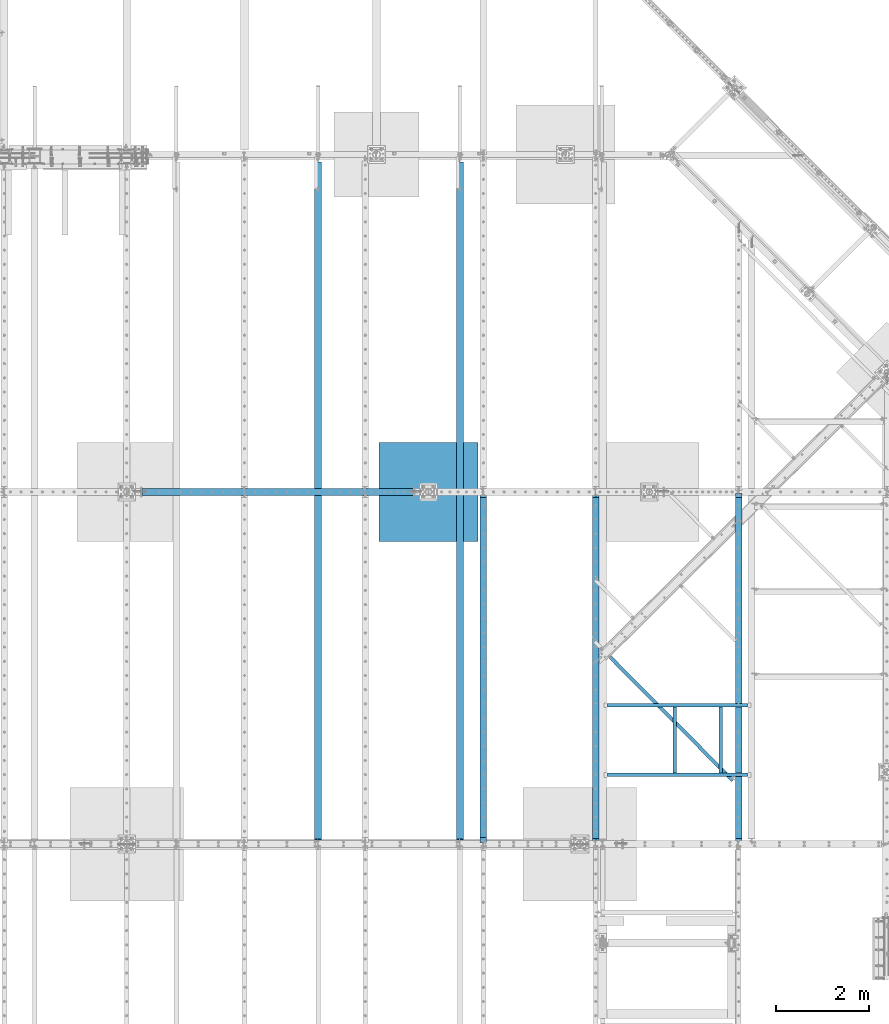
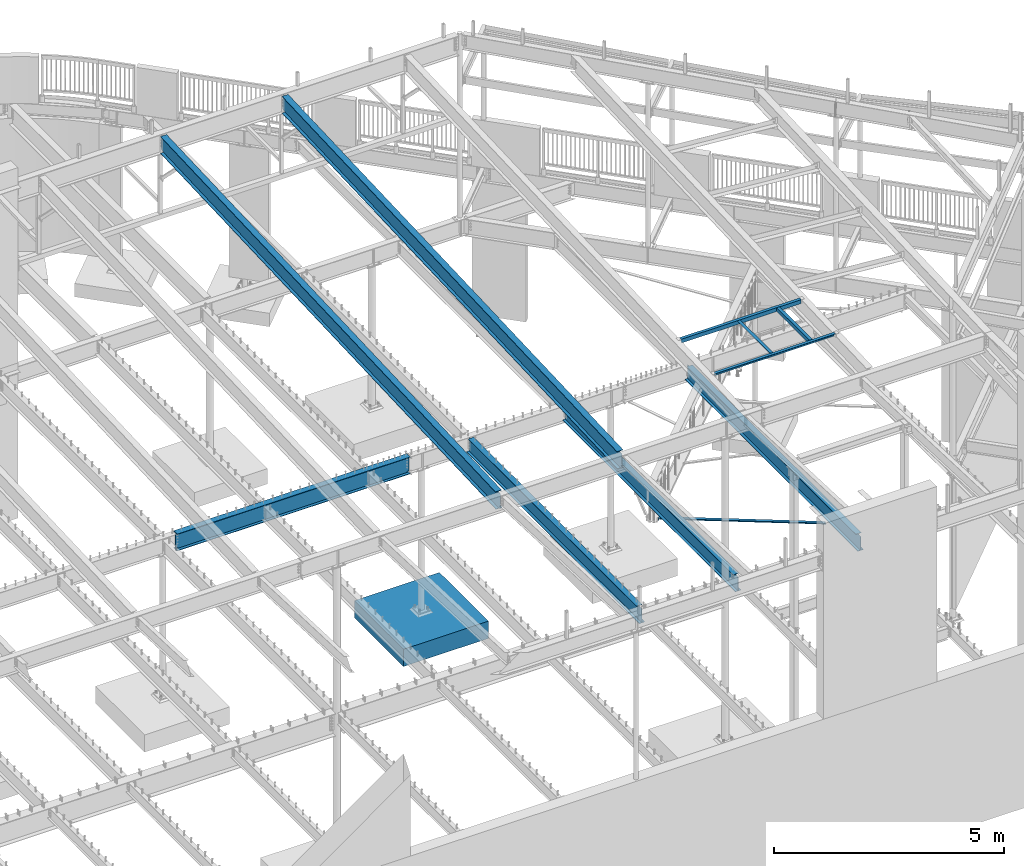
# One storey, part 317 of 975: 12 beams.
"""IFC2X3 building model written with IfcOpenShell, lengths in millimetres."""

from ifc_helpers import new_model, si_unit, frame, origin_with_axes, place, context, subcontext, project, spatial, faceted_brep, material, type_object, element, save


model = new_model("IFC2X3")

# Units and contexts
model_context = context("Model", 3, precision=1e-05, world=origin_with_axes())
body_context = subcontext(model_context, "Body", "Model", "MODEL_VIEW")
ifc_project = project(units=[si_unit("LENGTHUNIT", "METRE", prefix="MILLI"), si_unit("AREAUNIT", "SQUARE_METRE"), si_unit("VOLUMEUNIT", "CUBIC_METRE"), si_unit("MASSUNIT", "GRAM", prefix="KILO"), si_unit("TIMEUNIT", "SECOND"), si_unit("PLANEANGLEUNIT", "RADIAN"), si_unit("SOLIDANGLEUNIT", "STERADIAN"), si_unit("THERMODYNAMICTEMPERATUREUNIT", "DEGREE_CELSIUS"), si_unit("LUMINOUSINTENSITYUNIT", "LUMEN")], contexts=[model_context])

# Site, building, storey
site_placement = place(None, origin_with_axes())
site = spatial("IfcSite", under=ifc_project, at=site_placement, CompositionType="ELEMENT")
building_placement = place(site_placement, origin_with_axes())
building = spatial("IfcBuilding", under=site, at=building_placement, Name="Undefined", CompositionType="ELEMENT")
storey_placement = place(building_placement, origin_with_axes())
storey = spatial("IfcBuildingStorey", under=building, at=storey_placement, Name="Undefined", CompositionType="ELEMENT", Elevation=0.0)

# Beams
ifc_material_1 = material(Name="STEEL/A36")
beam_type_1 = type_object("IfcBeamType", Name="L3X3X3/16", PredefinedType="NOTDEFINED")
beam_1_placement = place(storey_placement, frame((23906.3912854888, 9816.87831160247, 2870.2), z_axis=(-0.709199630836852, -0.705007718837796, 0.0), x_axis=(0.0, 0.0, 1.0)))
element("IfcBeam", 1, at=beam_1_placement, inside=storey, type_object=beam_type_1, material=ifc_material_1, Name="ANGLE", ObjectType="L3X3X3/16", context=body_context, shape_type="Brep", body=[
    faceted_brep([(25.3999991016485, 33.3375000005835, 38.1000564628812), (25.4000018705901, 38.1000000005915, 38.1000564628885), (25.4000018418292, 38.100000000657, -38.0999435372178), (25.3999990728876, 33.3374606629004, -38.1001501021346), (25.3999990746852, 33.3375000006454, -33.3374435372207), (87.9656692672388, 33.3375000124943, -33.3373044571854), (87.9656692654412, 33.3374606295438, -38.099937640236), (17.2974222805042, 22.8805155612699, -38.0999615488181), (17.2974222808862, 22.8805549429017, -33.3374615488137), (26.3940511142555, -38.5946475536875, -33.3371779727895), (26.3210864210287, -38.0999999994438, -33.3374414897553), (26.3211297871808, -38.0999999994419, -38.0999414896651), (26.3940672015779, -38.5946847264931, -38.0996779726156), (571.069093997022, -3719.51957603081, -38.0691073324269), (571.069077934182, -3719.51953902345, -33.3066073326008), (101.773291179968, -27.4406454407417, -38.0995104087415), (92.0753515031388, 38.1000000021377, -38.099795321592), (92.0746576447095, 38.1000000020686, 38.1002046769718), (101.773033782809, -27.4400506758284, 38.1004895884216), (646.448060967117, -3708.36494460809, 38.1310602286285), (646.448317972562, -3708.36553672579, -38.0689397685564), (641.73710041125, -3709.06262717499, -33.3064502414745), (641.736859468646, -3709.06207206465, 38.1310497558879), (97.0618322841592, -28.1371781311864, 38.1004791156811), (87.9650187874622, 33.3375000019751, 38.1001955414686), (97.0620735939965, -28.1377357232959, -33.3370208816596), (25.821086420955, -34.7225405137397, -33.3374426012269), (25.8210970077298, -34.7226514435897, -38.0999426012095)], [[[0, 1, 2, 3, 4]], [[5, 6, 7, 8]], [[4, 3, 6, 5]], [[9, 10, 11, 12, 13, 14]], [[15, 16, 17, 18, 19, 20]], [[21, 14, 13, 20, 19, 22]], [[23, 24, 5, 25, 21, 22]], [[26, 10, 9, 14, 21, 25, 5, 8]], [[27, 11, 10, 26, 8, 7]], [[2, 16, 15, 20, 13, 12, 11, 27, 7, 6, 3]], [[17, 16, 2, 1]], [[24, 23, 22, 19, 18, 17, 1, 0]], [[5, 24, 0, 4]]]),
])
beam_type_2 = type_object("IfcBeamType", Name="L4X3X1/4", PredefinedType="NOTDEFINED")
for number, where, z_axis, x_axis, name in (
    (2, (26260.425, 8766.17499989342, 8303.80592173534), (0.0, 0.0, -1.0), (0.0, -1.0, 0.0), "ANGLE"),
    (3, (25269.825, 7343.77500010658, 8303.80592173534), (0.0, 0.0, -1.0), (0.0, 1.0, 0.0), "ANGLE"),
):
    element("IfcBeam", number, at=place(storey_placement, frame(where, z_axis=z_axis, x_axis=x_axis)), inside=storey, type_object=beam_type_2, material=ifc_material_1, Name=name, ObjectType="L4X3X1/4", context=body_context, shape_type="Brep", body=[
        faceted_brep([(0.0, 38.0999999999985, -50.7999999999993), (0.0, 38.0999999999985, 50.7999999999993), (1422.39999978684, 38.0999999999985, 50.7999999999993), (1422.39999978684, 38.0999999999985, -50.7999999999993), (0.0, 31.75, 50.7999999999993), (1422.39999978684, 31.75, 50.7999999999993), (0.0, 31.75, -44.4500000000007), (1422.39999978684, 31.75, -44.4500000000007), (0.0, -38.0999999999985, -44.4500000000007), (1422.39999978684, -38.0999999999985, -44.4500000000007), (0.0, -38.0999999999985, -50.7999999999993), (1422.39999978684, -38.0999999999985, -50.7999999999993)], [[[0, 1, 2, 3]], [[1, 4, 5, 2]], [[4, 6, 7, 5]], [[6, 8, 9, 7]], [[8, 10, 11, 9]], [[10, 0, 3, 11]], [[5, 7, 9, 11, 3, 2]], [[10, 8, 6, 4, 1, 0]]]),
    ])
for number, where, z_axis, x_axis, name in (
    (4, (26838.275, 7305.67500010658, 8303.80592173534), (0.0, 0.0, -1.0), (-0.999999999999998, 6.90000001668524e-08, 0.0), "ANGLE"),
    (5, (23825.2, 8804.27499989342, 8303.80592173534), (0.0, 0.0, -1.0), (1.0, 0.0, 0.0), "FRAME"),
):
    element("IfcBeam", number, at=place(storey_placement, frame(where, z_axis=z_axis, x_axis=x_axis)), inside=storey, type_object=beam_type_2, material=ifc_material_1, Name=name, ObjectType="L4X3X1/4", context=body_context, shape_type="Brep", body=[
        faceted_brep([(0.0, 38.0999999999985, -50.7999999999993), (0.0, 38.0999999999985, 50.7999999999993), (3013.075, 38.1000000000004, 50.7999999999993), (3013.075, 38.1000000000004, -50.7999999999993), (0.0, 31.75, 50.7999999999993), (3013.075, 31.75, 50.7999999999993), (0.0, 31.75, -44.4500000000007), (3013.075, 31.75, -44.4500000000007), (0.0, -38.0999999999985, -44.4500000000007), (3013.075, -38.1000000000004, -44.4500000000007), (0.0, -38.0999999999985, -50.7999999999993), (3013.075, -38.1000000000004, -50.7999999999993)], [[[0, 1, 2, 3]], [[1, 4, 5, 2]], [[4, 6, 7, 5]], [[6, 8, 9, 7]], [[8, 10, 11, 9]], [[10, 0, 3, 11]], [[5, 7, 9, 11, 3, 2]], [[10, 8, 6, 4, 1, 0]]]),
    ])
ifc_material_2 = material(Name="STEEL/A992")
beam_type_3 = type_object("IfcBeamType", Name="W18X40", PredefinedType="NOTDEFINED")
beam_2_placement = place(storey_placement, frame((20653.375, 5829.11637334778, 8002.77977754138), z_axis=(0.0, -0.0411491589862163, 0.999153014665285), x_axis=(0.0, 0.999153014665285, 0.0411491589862177)))
element("IfcBeam", 6, at=beam_2_placement, inside=storey, type_object=beam_type_3, material=ifc_material_2, Name="BEAM", ObjectType="W18X40", context=body_context, shape_type="Brep", body=[
    faceted_brep([(14657.5609744888, -76.2000000000007, -214.312499994021), (14657.5609744888, -76.2000000000007, -227.012499992623), (14657.5609744888, 76.2000000000007, -227.012499994023), (14657.5609744888, 76.2000000000007, -214.312499994021), (14657.5609744888, 3.96875, -214.312499994021), (14657.5609744888, -3.96875, -214.312499994021), (14658.5277044114, 3.96865543364765, -209.452420103776), (14658.5277044114, -3.96875, -209.452420103776), (14661.2807183119, 3.96865541555962, -205.332243635633), (14661.2807183119, -3.96875, -205.332243635633), (14665.40089478, 3.9686554016771, -202.579229735162), (14665.40089478, -3.96875, -202.579229735162), (14670.2609742981, 3.9686553941101, -201.612499812572), (14670.2609742981, -3.96875, -201.612499812572), (14765.5109744548, -3.96875, -201.612499812583), (14765.5109744548, 3.96875, -201.612499812583), (109.117370300622, 3.96875, 214.312500000065), (109.117370300622, 76.2000000000007, 214.312500000065), (14676.6109744899, 76.2000000000007, 214.312500006024), (14676.6109744899, 3.96875, 214.312500006024), (71.0173703004075, -3.96875, -207.962499809312), (71.0173703004075, 3.96875, -207.962499809312), (71.0173703004093, 3.96875, -214.312499999988), (71.0173703004093, 76.2000000000007, -214.312499999988), (71.0173703004139, 76.2000000000007, -227.012499999989), (71.0173703004148, -76.2000000000007, -227.012499809476), (71.0173703004093, -76.2000000000007, -214.312499999988), (71.0173703004093, -3.96875, -214.312499999988), (70.0506403778163, -3.96875, -203.102420291266), (70.0506403778163, 3.96875, -203.102420291266), (67.2976264773361, -3.96875, -198.982243823111), (67.2976264773361, 3.96875, -198.982243823111), (63.1774500091806, -3.96875, -196.229229922636), (63.1774500091806, 3.96875, -196.229229922636), (58.3173704911333, -3.96875, -195.262500000049), (58.3173704911333, 3.96875, -195.262500000049), (8.8249636104365, -3.96875, -195.262500000069), (8.8249636104365, 3.96875, -195.262500000069), (24.9083613255289, -3.96875, 195.262500000009), (24.9083613255289, 3.96875, 195.262500000009), (96.4173704913837, -3.96875, 195.262500000037), (96.4173704913837, 3.96875, 195.262500000037), (101.277450009429, -3.96875, 196.229229922624), (101.277450009429, 3.96875, 196.229229922624), (105.397626477584, -3.96875, 198.9822438231), (105.397626477584, 3.96875, 198.9822438231), (108.15064037806, -3.96875, 203.102420291253), (108.15064037806, 3.96875, 203.102420291253), (109.117370300646, -3.96875, 207.962499809298), (109.117370300646, 3.96875, 207.962499809298), (109.117370300628, -76.2000000000007, 227.012500000065), (109.117370300628, 76.2000000000007, 227.012500000065), (109.117370300622, -3.96875, 214.312500000065), (109.117370300622, -76.2000000000007, 214.312500000065), (14676.6109744899, -3.96875, 214.312500006024), (14676.6109744899, -76.2000000000007, 214.312500006024), (14676.6109744899, -76.2000000000007, 227.012500006025), (14676.6109744899, 76.2000000000007, 227.012500006025), (14677.5777044125, -3.96875, 209.452420478925), (14677.5777044125, 3.96826458708529, 209.452420478925), (14680.330718313, -3.96875, 205.332244010762), (14680.330718313, 3.96826481508469, 205.332244010762), (14684.4508947812, -3.96875, 202.579230110274), (14684.4508947812, 3.96826496742869, 202.579230110274), (14689.3109742992, -3.96875, 201.612500187682), (14689.3109742992, 3.96826502092517, 201.612500187682), (14765.5109744548, -3.96875, 201.612500187783), (14765.5109744548, 3.96875, 201.612500187783)], [[[0, 1, 2, 3, 4, 5]], [[5, 4, 6, 7]], [[7, 6, 8, 9]], [[9, 8, 10, 11]], [[11, 10, 12, 13]], [[14, 13, 12, 15]], [[16, 17, 18, 19]], [[20, 21, 22, 23, 24, 25, 26, 27]], [[28, 29, 21, 20]], [[30, 31, 29, 28]], [[32, 33, 31, 30]], [[34, 35, 33, 32]], [[36, 37, 35, 34]], [[38, 39, 37, 36]], [[40, 41, 39, 38]], [[42, 43, 41, 40]], [[44, 45, 43, 42]], [[46, 47, 45, 44]], [[48, 49, 47, 46]], [[50, 51, 17, 16, 49, 48, 52, 53]], [[53, 52, 54, 55]], [[50, 53, 55, 56]], [[51, 50, 56, 57]], [[17, 51, 57, 18]], [[56, 55, 54, 19, 18, 57]], [[58, 59, 19, 54]], [[60, 61, 59, 58]], [[62, 63, 61, 60]], [[64, 65, 63, 62]], [[66, 67, 65, 64]], [[67, 66, 14, 15]], [[10, 8, 6, 4, 22, 21, 29, 31, 33, 35, 37, 39, 41, 43, 45, 47, 49, 16, 19, 59, 61, 63, 65, 67, 15, 12]], [[23, 22, 4, 3]], [[24, 23, 3, 2]], [[25, 24, 2, 1]], [[26, 25, 1, 0]], [[27, 26, 0, 5]], [[66, 64, 62, 60, 58, 54, 52, 48, 46, 44, 42, 40, 38, 36, 34, 32, 30, 28, 20, 27, 5, 7, 9, 11, 13, 14]]]),
])
beam_3_placement = place(storey_placement, frame((17605.375, 5829.11637334778, 8002.77977754138), z_axis=(0.0, -0.0411491589862163, 0.999153014665285), x_axis=(0.0, 0.999153014665285, 0.0411491589862177)))
element("IfcBeam", 7, at=beam_3_placement, inside=storey, type_object=beam_type_3, material=ifc_material_2, Name="BEAM", ObjectType="W18X40", context=body_context, shape_type="Brep", body=[
    faceted_brep([(14657.5609744888, -76.2000000000007, -214.312499994021), (14657.5609744888, -76.2000000000007, -227.012499992623), (14657.5609744888, 76.2000000000007, -227.012499994023), (14657.5609744888, 76.2000000000007, -214.312499994021), (14657.5609744888, 3.96875, -214.312499994021), (14657.5609744888, -3.96875, -214.312499994021), (14658.5277044114, 3.96865543364765, -209.452420103776), (14658.5277044114, -3.96875, -209.452420103776), (14661.2807183119, 3.96865541555962, -205.332243635633), (14661.2807183119, -3.96875, -205.332243635633), (14665.40089478, 3.9686554016771, -202.579229735162), (14665.40089478, -3.96875, -202.579229735162), (14670.2609742981, 3.9686553941101, -201.612499812572), (14670.2609742981, -3.96875, -201.612499812572), (14765.5109744548, -3.96875, -201.612499812583), (14765.5109744548, 3.96875, -201.612499812583), (109.117370300622, 3.96875, 214.312500000065), (109.117370300622, 76.2000000000007, 214.312500000065), (14676.6109744899, 76.2000000000007, 214.312500006024), (14676.6109744899, 3.96875, 214.312500006024), (71.0173703004075, -3.96875, -207.962499809312), (71.0173703004075, 3.96875, -207.962499809312), (71.0173703004093, 3.96875, -214.312499999988), (71.0173703004093, 76.2000000000007, -214.312499999988), (71.0173703004139, 76.2000000000007, -227.012499999989), (71.0173703004148, -76.2000000000007, -227.012499809476), (71.0173703004093, -76.2000000000007, -214.312499999988), (71.0173703004093, -3.96875, -214.312499999988), (70.0506403778163, -3.96875, -203.102420291266), (70.0506403778163, 3.96875, -203.102420291266), (67.2976264773361, -3.96875, -198.982243823111), (67.2976264773361, 3.96875, -198.982243823111), (63.1774500091806, -3.96875, -196.229229922636), (63.1774500091806, 3.96875, -196.229229922636), (58.3173704911333, -3.96875, -195.262500000049), (58.3173704911333, 3.96875, -195.262500000049), (8.8249636104365, -3.96875, -195.262500000069), (8.8249636104365, 3.96875, -195.262500000069), (24.9083613255289, -3.96875, 195.262500000009), (24.9083613255289, 3.96875, 195.262500000009), (96.4173704913837, -3.96875, 195.262500000037), (96.4173704913837, 3.96875, 195.262500000037), (101.277450009429, -3.96875, 196.229229922624), (101.277450009429, 3.96875, 196.229229922624), (105.397626477584, -3.96875, 198.9822438231), (105.397626477584, 3.96875, 198.9822438231), (108.15064037806, -3.96875, 203.102420291253), (108.15064037806, 3.96875, 203.102420291253), (109.117370300646, -3.96875, 207.962499809298), (109.117370300646, 3.96875, 207.962499809298), (109.117370300628, -76.2000000000007, 227.012500000065), (109.117370300628, 76.2000000000007, 227.012500000065), (109.117370300622, -3.96875, 214.312500000065), (109.117370300622, -76.2000000000007, 214.312500000065), (14676.6109744899, -3.96875, 214.312500006024), (14676.6109744899, -76.2000000000007, 214.312500006024), (14676.6109744899, -76.2000000000007, 227.012500006025), (14676.6109744899, 76.2000000000007, 227.012500006025), (14677.5777044125, -3.96875, 209.452420478925), (14677.5777044125, 3.96826458708529, 209.452420478925), (14680.330718313, -3.96875, 205.332244010762), (14680.330718313, 3.96826481508469, 205.332244010762), (14684.4508947812, -3.96875, 202.579230110274), (14684.4508947812, 3.96826496742869, 202.579230110274), (14689.3109742992, -3.96875, 201.612500187682), (14689.3109742992, 3.96826502092517, 201.612500187682), (14765.5109744548, -3.96875, 201.612500187783), (14765.5109744548, 3.96875, 201.612500187783)], [[[0, 1, 2, 3, 4, 5]], [[5, 4, 6, 7]], [[7, 6, 8, 9]], [[9, 8, 10, 11]], [[11, 10, 12, 13]], [[14, 13, 12, 15]], [[16, 17, 18, 19]], [[20, 21, 22, 23, 24, 25, 26, 27]], [[28, 29, 21, 20]], [[30, 31, 29, 28]], [[32, 33, 31, 30]], [[34, 35, 33, 32]], [[36, 37, 35, 34]], [[38, 39, 37, 36]], [[40, 41, 39, 38]], [[42, 43, 41, 40]], [[44, 45, 43, 42]], [[46, 47, 45, 44]], [[48, 49, 47, 46]], [[50, 51, 17, 16, 49, 48, 52, 53]], [[53, 52, 54, 55]], [[50, 53, 55, 56]], [[51, 50, 56, 57]], [[17, 51, 57, 18]], [[56, 55, 54, 19, 18, 57]], [[58, 59, 19, 54]], [[60, 61, 59, 58]], [[62, 63, 61, 60]], [[64, 65, 63, 62]], [[66, 67, 65, 64]], [[67, 66, 14, 15]], [[10, 8, 6, 4, 22, 21, 29, 31, 33, 35, 37, 39, 41, 43, 45, 47, 49, 16, 19, 59, 61, 63, 65, 67, 15, 12]], [[23, 22, 4, 3]], [[24, 23, 3, 2]], [[25, 24, 2, 1]], [[26, 25, 1, 0]], [[27, 26, 0, 5]], [[66, 64, 62, 60, 58, 54, 52, 48, 46, 44, 42, 40, 38, 36, 34, 32, 30, 28, 20, 27, 5, 7, 9, 11, 13, 14]]]),
])
beam_type_4 = type_object("IfcBeamType", Name="W16X26", PredefinedType="NOTDEFINED")
beam_4_placement = place(storey_placement, frame((26644.6, 5819.775, 3736.975), z_axis=(0.0, 0.0, 1.0), x_axis=(0.0, 1.0, 0.0)))
element("IfcBeam", 8, at=beam_4_placement, inside=storey, type_object=beam_type_4, material=ifc_material_2, Name="BEAM", ObjectType="W16X26", context=body_context, shape_type="Brep", body=[
    faceted_brep([(105.568750190729, -3.17499999999927, 174.625), (105.568750190729, 3.17499999999927, 174.625), (29.368749999996, 3.17499999999927, 174.625), (29.368749999996, -3.17499999999927, 174.625), (110.428829708775, -3.17499999999927, 175.591729922588), (110.428829708775, 3.17499999999927, 175.591729922588), (114.549006176929, -3.17499999999927, 178.344743823066), (114.549006176929, 3.17499999999927, 178.344743823066), (117.302020077406, -3.17499999999927, 182.46492029122), (117.302020077406, 3.17499999999927, 182.46492029122), (118.268749999994, -3.17499999999927, 187.324999809266), (118.268749999994, 3.17499999999927, 187.324999809266), (118.268749999994, -69.8499999999985, 200.024999810586), (118.268749999994, 69.8499999999985, 200.025), (118.268749999994, 69.8499999999985, 190.5), (118.268749999994, 3.17499999999927, 190.5), (118.268749999994, -3.17499999999927, 190.5), (118.268749999994, -69.8499999999985, 190.5), (29.368749999996, -3.17499999999927, -190.5), (29.368749999996, -69.8499999999985, -190.5), (7543.00625, -69.8499999999985, -190.5), (7543.00625, -3.17499999999927, -190.5), (29.368749999996, -69.8499999999985, -200.025), (7543.00625, -69.8499999999985, -200.025), (29.368749999996, 69.8499999999985, -200.025), (7543.00625, 69.8499999999985, -200.025), (29.368749999996, 69.8499999999985, -190.5), (7543.00625, 69.8499999999985, -190.5), (29.368749999996, 3.17499999999927, -190.5), (7543.00625, 3.17499999999927, -190.5), (7543.00625, 3.17499999999927, 174.625), (7543.00625, -3.17499999999927, 174.625), (7466.80624980926, 3.17499999999927, 174.625), (7466.80624980926, -3.17499999999927, 174.625), (7461.94617029122, 3.17499999999927, 175.591729922588), (7461.94617029122, -3.17499999999927, 175.591729922588), (7457.82599382307, 3.17499999999927, 178.344743823066), (7457.82599382307, -3.17499999999927, 178.344743823066), (7455.07297992259, 3.17499999999927, 182.46492029122), (7455.07297992259, -3.17499999999927, 182.46492029122), (7454.10625, 3.17499999999927, 187.324999809266), (7454.10625, -3.17499999999927, 187.324999809266), (7454.10625, -69.8499999999985, 200.025), (7454.10625, -69.8499999999985, 190.5), (7454.10625, -3.17499999999927, 190.5), (7454.10625, 3.17499999999927, 190.5), (7454.10625, 69.8499999999985, 190.5), (7454.10625, 69.8499999999985, 200.025)], [[[0, 1, 2, 3]], [[4, 5, 1, 0]], [[6, 7, 5, 4]], [[8, 9, 7, 6]], [[10, 11, 9, 8]], [[12, 13, 14, 15, 11, 10, 16, 17]], [[18, 19, 20, 21]], [[19, 22, 23, 20]], [[22, 24, 25, 23]], [[24, 26, 27, 25]], [[26, 28, 29, 27]], [[21, 20, 23, 25, 27, 29, 30, 31]], [[31, 30, 32, 33]], [[33, 32, 34, 35]], [[35, 34, 36, 37]], [[37, 36, 38, 39]], [[39, 38, 40, 41]], [[42, 43, 44, 41, 40, 45, 46, 47]], [[43, 42, 12, 17]], [[44, 43, 17, 16]], [[8, 6, 4, 0, 3, 18, 21, 31, 33, 35, 37, 39, 41, 44, 16, 10]], [[28, 26, 24, 22, 19, 18, 3, 2]], [[45, 40, 38, 36, 34, 32, 30, 29, 28, 2, 1, 5, 7, 9, 11, 15]], [[46, 45, 15, 14]], [[47, 46, 14, 13]], [[42, 47, 13, 12]]]),
])
beam_5_placement = place(storey_placement, frame((23571.2, 5819.775, 3736.975), z_axis=(0.0, 0.0, 1.0), x_axis=(0.0, 1.0, 0.0)))
element("IfcBeam", 9, at=beam_5_placement, inside=storey, type_object=beam_type_4, material=ifc_material_2, Name="BEAM", ObjectType="W16X26", context=body_context, shape_type="Brep", body=[
    faceted_brep([(105.568750190729, -3.17499999999927, 174.625), (105.568750190729, 3.17499999999927, 174.625), (29.368749999996, 3.17499999999927, 174.625), (29.368749999996, -3.17499999999927, 174.625), (110.428829708775, -3.17499999999927, 175.591729922588), (110.428829708775, 3.17499999999927, 175.591729922588), (114.549006176929, -3.17499999999927, 178.344743823066), (114.549006176929, 3.17499999999927, 178.344743823066), (117.302020077406, -3.17499999999927, 182.46492029122), (117.302020077406, 3.17499999999927, 182.46492029122), (118.268749999994, -3.17499999999927, 187.324999809266), (118.268749999994, 3.17499999999927, 187.324999809266), (118.268749999994, -69.8499999999985, 200.024999810586), (118.268749999994, 69.8499999999985, 200.025), (118.268749999994, 69.8499999999985, 190.5), (118.268749999994, 3.17499999999927, 190.5), (118.268749999994, -3.17499999999927, 190.5), (118.268749999994, -69.8499999999985, 190.5), (29.368749999996, -3.17499999999927, -190.5), (29.368749999996, -69.8499999999985, -190.5), (7543.00625, -69.8499999999985, -190.5), (7543.00625, -3.17499999999927, -190.5), (29.368749999996, -69.8499999999985, -200.025), (7543.00625, -69.8499999999985, -200.025), (29.368749999996, 69.8499999999985, -200.025), (7543.00625, 69.8499999999985, -200.025), (29.368749999996, 69.8499999999985, -190.5), (7543.00625, 69.8499999999985, -190.5), (29.368749999996, 3.17499999999927, -190.5), (7543.00625, 3.17499999999927, -190.5), (7543.00625, 3.17499999999927, 174.625), (7543.00625, -3.17499999999927, 174.625), (7466.80624980926, 3.17499999999927, 174.625), (7466.80624980926, -3.17499999999927, 174.625), (7461.94617029122, 3.17499999999927, 175.591729922588), (7461.94617029122, -3.17499999999927, 175.591729922588), (7457.82599382307, 3.17499999999927, 178.344743823066), (7457.82599382307, -3.17499999999927, 178.344743823066), (7455.07297992259, 3.17499999999927, 182.46492029122), (7455.07297992259, -3.17499999999927, 182.46492029122), (7454.10625, 3.17499999999927, 187.324999809266), (7454.10625, -3.17499999999927, 187.324999809266), (7454.10625, -69.8499999999985, 200.025), (7454.10625, -69.8499999999985, 190.5), (7454.10625, -3.17499999999927, 190.5), (7454.10625, 3.17499999999927, 190.5), (7454.10625, 69.8499999999985, 190.5), (7454.10625, 69.8499999999985, 200.025)], [[[0, 1, 2, 3]], [[4, 5, 1, 0]], [[6, 7, 5, 4]], [[8, 9, 7, 6]], [[10, 11, 9, 8]], [[12, 13, 14, 15, 11, 10, 16, 17]], [[18, 19, 20, 21]], [[19, 22, 23, 20]], [[22, 24, 25, 23]], [[24, 26, 27, 25]], [[26, 28, 29, 27]], [[21, 20, 23, 25, 27, 29, 30, 31]], [[31, 30, 32, 33]], [[33, 32, 34, 35]], [[35, 34, 36, 37]], [[37, 36, 38, 39]], [[39, 38, 40, 41]], [[42, 43, 44, 41, 40, 45, 46, 47]], [[43, 42, 12, 17]], [[44, 43, 17, 16]], [[8, 6, 4, 0, 3, 18, 21, 31, 33, 35, 37, 39, 41, 44, 16, 10]], [[28, 26, 24, 22, 19, 18, 3, 2]], [[45, 40, 38, 36, 34, 32, 30, 29, 28, 2, 1, 5, 7, 9, 11, 15]], [[46, 45, 15, 14]], [[47, 46, 14, 13]], [[42, 47, 13, 12]]]),
])
beam_6_placement = place(storey_placement, frame((21158.2, 5819.775, 3736.975), z_axis=(0.0, 0.0, 1.0), x_axis=(0.0, 1.0, 0.0)))
element("IfcBeam", 10, at=beam_6_placement, inside=storey, type_object=beam_type_4, material=ifc_material_2, Name="BEAM", ObjectType="W16X26", context=body_context, shape_type="Brep", body=[
    faceted_brep([(126.206250190731, -3.17499999999927, 174.625), (126.206250190731, 3.17499999999927, 174.625), (30.9562499999956, 3.17499999999927, 174.625), (30.9562499999956, -3.17499999999927, 174.625), (131.066329708777, -3.17499999999927, 175.591729922588), (131.066329708777, 3.17499999999927, 175.591729922588), (135.18650617693, -3.17499999999927, 178.344743823066), (135.18650617693, 3.17499999999927, 178.344743823066), (137.939520077409, -3.17499999999927, 182.46492029122), (137.939520077409, 3.17499999999927, 182.46492029122), (138.906249999996, -3.17499999999927, 187.324999809266), (138.906249999996, 3.17499999999927, 187.324999809266), (138.906249999996, -69.8499999999985, 200.025), (138.906249999996, 69.8499999999985, 200.025), (138.906249999996, 69.8499999999985, 190.5), (138.906249999996, 3.17499999999927, 190.5), (138.906249999996, -3.17499999999927, 190.5), (138.906249999996, -69.8499999999985, 190.5), (30.9562499999956, -3.17499999999927, -190.5), (30.9562499999956, -69.8499999999985, -190.5), (7543.00625, -69.8499999999985, -190.5), (7543.00625, -3.17499999999927, -190.5), (30.9562499999956, -69.8499999999985, -200.025), (7543.00625, -69.8499999999985, -200.025), (30.9562499999956, 69.8499999999985, -200.025), (7543.00625, 69.8499999999985, -200.025), (30.9562499999956, 69.8499999999985, -190.5), (7543.00625, 69.8499999999985, -190.5), (30.9562499999956, 3.17499999999927, -190.5), (7543.00625, 3.17499999999927, -190.5), (7543.00625, 3.17499999999927, 174.625), (7543.00625, -3.17499999999927, 174.625), (7466.80624980926, 3.17499999999927, 174.625), (7466.80624980926, -3.17499999999927, 174.625), (7461.94617029122, 3.17499999999927, 175.591729922588), (7461.94617029122, -3.17499999999927, 175.591729922588), (7457.82599382307, 3.17499999999927, 178.344743823066), (7457.82599382307, -3.17499999999927, 178.344743823066), (7455.07297992259, 3.17499999999927, 182.46492029122), (7455.07297992259, -3.17499999999927, 182.46492029122), (7454.10625, 3.17499999999927, 187.324999809266), (7454.10625, -3.17499999999927, 187.324999809266), (7454.10625, -69.8499999999985, 200.025), (7454.10625, -69.8499999999985, 190.5), (7454.10625, -3.17499999999927, 190.5), (7454.10625, 3.17499999999927, 190.5), (7454.10625, 69.8499999999985, 190.5), (7454.10625, 69.8499999999985, 200.025)], [[[0, 1, 2, 3]], [[4, 5, 1, 0]], [[6, 7, 5, 4]], [[8, 9, 7, 6]], [[10, 11, 9, 8]], [[12, 13, 14, 15, 11, 10, 16, 17]], [[18, 19, 20, 21]], [[19, 22, 23, 20]], [[22, 24, 25, 23]], [[24, 26, 27, 25]], [[26, 28, 29, 27]], [[21, 20, 23, 25, 27, 29, 30, 31]], [[31, 30, 32, 33]], [[33, 32, 34, 35]], [[35, 34, 36, 37]], [[37, 36, 38, 39]], [[39, 38, 40, 41]], [[42, 43, 44, 41, 40, 45, 46, 47]], [[43, 42, 12, 17]], [[44, 43, 17, 16]], [[8, 6, 4, 0, 3, 18, 21, 31, 33, 35, 37, 39, 41, 44, 16, 10]], [[28, 26, 24, 22, 19, 18, 3, 2]], [[45, 40, 38, 36, 34, 32, 30, 29, 28, 2, 1, 5, 7, 9, 11, 15]], [[46, 45, 15, 14]], [[47, 46, 14, 13]], [[42, 47, 13, 12]]]),
])
beam_type_5 = type_object("IfcBeamType", Name="W18X35", PredefinedType="NOTDEFINED")
beam_7_placement = place(storey_placement, frame((13798.55, 13392.15, 3711.575), z_axis=(0.0, 0.0, 1.0), x_axis=(1.0, 0.0, 0.0)))
element("IfcBeam", 11, at=beam_7_placement, inside=storey, type_object=beam_type_5, material=ifc_material_2, Name="BEAM", ObjectType="W18X35", context=body_context, shape_type="Brep", body=[
    faceted_brep([(14.287031462678, -76.1999999999998, 225.425), (14.287031462678, 76.1999999999998, 225.425), (3.17496870515606, 76.1999999999998, 214.312499999999), (3.17496870515606, 3.96875, 214.312499999999), (2.77798382235414, 3.96875, 213.915499496458), (2.77798382235414, -3.96875, 213.915499496458), (3.17496870515606, -3.96875, 214.312499999999), (3.17496870515606, -76.1999999999998, 214.312499999999), (22.2250007629409, -3.96875, 213.915499496458), (22.2250007629409, 3.96875, 213.915499496458), (40.7122683048001, 3.96875, 203.575605287907), (40.7122683048001, -3.96875, 203.575605287907), (44.8249534620081, 3.96875, 198.997422721183), (44.8249534620081, -3.96875, 198.997422721183), (45.2798117862694, 3.96875, 192.860074863892), (45.2798117862694, -3.96875, 192.860074863892), (41.8869600345242, 3.96875, 187.725633140859), (41.8869600345242, -3.96875, 187.725633140859), (36.0627638298283, 3.96875, 185.737499999999), (36.0627638298283, -3.96875, 185.737499999999), (6.34999999999854, 3.96875, 185.737499999999), (6.34999999999854, -3.96875, 185.737499999999), (6.34999999999854, 3.96875, -185.7375), (6.34999999999854, -3.96875, -185.7375), (47.9687625480874, 3.96875, -185.7375), (47.9687625480874, -3.96875, -185.7375), (53.7929587527833, 3.96875, -187.72563314086), (53.7929587527833, -3.96875, -187.72563314086), (57.1858105045285, 3.96875, -192.860074863893), (57.1858105045285, -3.96875, -192.860074863893), (56.7309521802672, 3.96875, -198.997422721185), (56.7309521802672, -3.96875, -198.997422721185), (52.6182670230592, 3.96875, -203.575605287907), (52.6182670230592, -3.96875, -203.575605287907), (34.1309994812, 3.96875, -213.91549949646), (34.1309994812, -3.96875, -213.91549949646), (14.6840158801024, 3.96875, -213.91549949646), (14.6840158801024, -3.96875, -213.91549949646), (5854.7004690027, 3.96875, -214.3125), (5854.7004690027, 76.2000000000007, -214.3125), (14.2870309973041, 76.1999999999998, -214.3125), (14.2870309973041, 3.96875, -214.3125), (5865.81253176022, 76.2000000000007, -225.425), (3.17496823977854, 76.1999999999998, -225.425), (5865.81253176022, -76.2000000000007, -225.425), (3.17496823977854, -76.1999999999998, -225.425), (5854.7004690027, -76.2000000000007, -214.3125), (14.2870309973041, -76.1999999999998, -214.3125), (14.2870309973041, -3.96875, -214.3125), (5854.7004690027, -3.96875, -214.3125), (5854.3034841199, 3.96875, -213.91549949646), (5854.3034841199, -3.96875, -213.91549949646), (5834.8565005188, 3.96875, -213.91549949646), (5834.8565005188, -3.96875, -213.91549949646), (5816.36923297694, 3.96875, -203.575605287907), (5816.36923297694, -3.96875, -203.575605287907), (5812.25654781974, 3.96875, -198.997422721185), (5812.25654781974, -3.96875, -198.997422721185), (5811.80168949547, 3.96875, -192.860074863893), (5811.80168949547, -3.96875, -192.860074863893), (5815.19454124722, 3.96875, -187.72563314086), (5815.19454124722, -3.96875, -187.72563314086), (5821.01873745192, 3.96875, -185.7375), (5821.01873745192, -3.96875, -185.7375), (5862.6375, 3.96875, -185.7375), (5862.6375, -3.96875, -185.7375), (5862.6375, -3.96875, 185.7375), (5862.6375, 3.96875, 185.7375), (5832.92473617017, 3.96875, 185.7375), (5832.92473617017, -3.96875, 185.7375), (5827.10053996548, 3.96875, 187.72563314086), (5827.10053996548, -3.96875, 187.72563314086), (5823.70768821373, 3.96875, 192.860074863893), (5823.70768821373, -3.96875, 192.860074863893), (5824.16254653799, 3.96875, 198.997422721185), (5824.16254653799, -3.96875, 198.997422721185), (5828.2752316952, 3.96875, 203.575605287907), (5828.2752316952, -3.96875, 203.575605287907), (5846.76249923706, 3.96875, 213.91549949646), (5846.76249923706, -3.96875, 213.91549949646), (5866.20951617765, 3.96875, 213.91549949646), (5866.20951617765, -3.96875, 213.91549949646), (5865.81253129485, 3.96875, 214.3125), (5865.81253129485, 76.2000000000007, 214.3125), (5854.70046853732, 76.2000000000007, 225.425), (5854.70046853732, -76.2000000000007, 225.425), (5865.81253129485, -76.2000000000007, 214.3125), (5865.81253129485, -3.96875, 214.3125)], [[[0, 1, 2, 3, 4, 5, 6, 7]], [[8, 9, 10, 11]], [[11, 10, 12, 13]], [[13, 12, 14, 15]], [[15, 14, 16, 17]], [[17, 16, 18, 19]], [[19, 18, 20, 21]], [[21, 20, 22, 23]], [[24, 25, 23, 22]], [[25, 24, 26, 27]], [[27, 26, 28, 29]], [[29, 28, 30, 31]], [[31, 30, 32, 33]], [[33, 32, 34, 35]], [[35, 34, 36, 37]], [[38, 39, 40, 41]], [[39, 42, 43, 40]], [[42, 44, 45, 43]], [[44, 46, 47, 45]], [[37, 36, 41, 40, 43, 45, 47, 48]], [[46, 49, 48, 47]], [[44, 42, 39, 38, 50, 51, 49, 46]], [[52, 53, 51, 50]], [[53, 52, 54, 55]], [[55, 54, 56, 57]], [[57, 56, 58, 59]], [[59, 58, 60, 61]], [[61, 60, 62, 63]], [[63, 62, 64, 65]], [[66, 65, 64, 67]], [[68, 69, 66, 67]], [[69, 68, 70, 71]], [[71, 70, 72, 73]], [[73, 72, 74, 75]], [[75, 74, 76, 77]], [[77, 76, 78, 79]], [[79, 78, 80, 81]], [[81, 80, 82, 83, 84, 85, 86, 87]], [[86, 85, 0, 7]], [[87, 86, 7, 6]], [[8, 11, 13, 15, 17, 19, 21, 23, 25, 27, 29, 31, 33, 35, 37, 48, 49, 51, 53, 55, 57, 59, 61, 63, 65, 66, 69, 71, 73, 75, 77, 79, 81, 87, 6, 5]], [[9, 8, 5, 4]], [[82, 80, 78, 76, 74, 72, 70, 68, 67, 64, 62, 60, 58, 56, 54, 52, 50, 38, 41, 36, 34, 32, 30, 28, 26, 24, 22, 20, 18, 16, 14, 12, 10, 9, 4, 3]], [[83, 82, 3, 2]], [[84, 83, 2, 1]], [[85, 84, 1, 0]]]),
])
ifc_material_3 = material(Name="CONCRETE/5000")
beam_type_6 = type_object("IfcBeamType", PredefinedType="NOTDEFINED")
beam_8_placement = place(storey_placement, frame((18911.8874938965, 13392.15, -533.4), z_axis=(0.0, 0.0, 1.0), x_axis=(1.0, 0.0, 0.0)))
element("IfcBeam", 12, at=beam_8_placement, inside=storey, type_object=beam_type_6, material=ifc_material_3, Name="FOOTING", context=body_context, shape_type="Brep", body=[
    faceted_brep([(0.0, 1066.8, -228.6), (0.0, 1066.8, 228.6), (2133.6, 1066.8, 228.6), (2133.6, 1066.8, -228.6), (0.0, -1066.8, 228.6), (2133.6, -1066.8, 228.6), (0.0, -1066.8, -228.6), (2133.6, -1066.8, -228.6)], [[[0, 1, 2, 3]], [[1, 4, 5, 2]], [[4, 6, 7, 5]], [[6, 0, 3, 7]], [[5, 7, 3, 2]], [[6, 4, 1, 0]]]),
])

save(model, "model.ifc")
